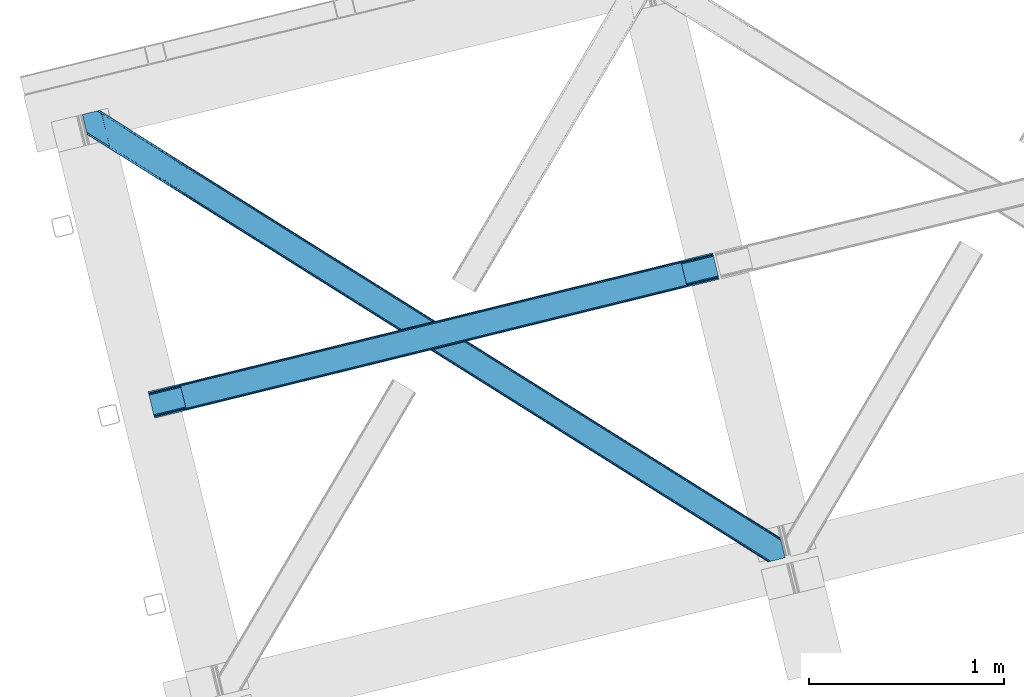
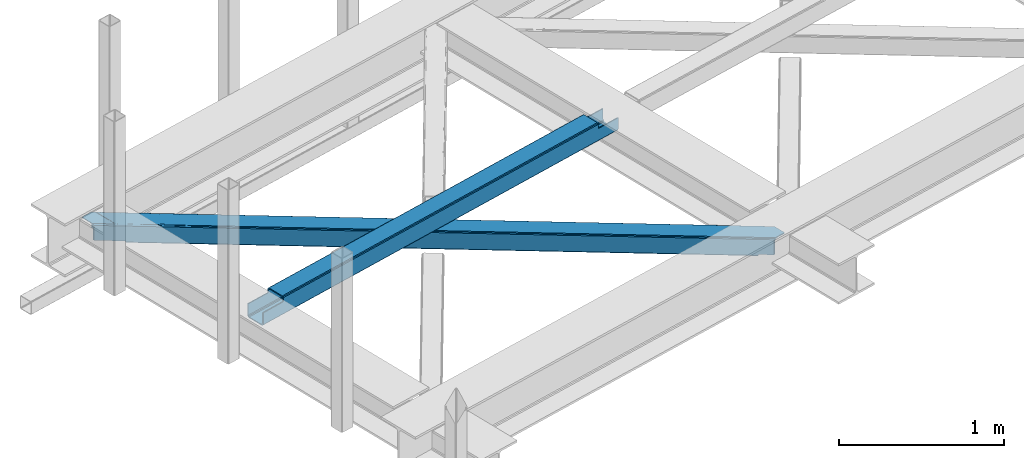
# One storey, part 18 of 67: 1 beam, 1 member.
"""IFC4 building model written with IfcOpenShell, lengths in millimetres."""

import ifcopenshell
import ifcopenshell.guid

model = None  # the IFC model being written
_history = None  # IfcOwnerHistory: only IFC2X3 demands one
_inside = {}  # id of a spatial element -> (the spatial element, [elements in it])
_under = {}  # id of a project, library or spatial element -> (it, [spatial elements below it])
_declared = {}  # id of a project -> (the project, [libraries it declares])
_typed = {}  # id of a type object -> (the type object, [elements of that type])
_made_of = {}  # id of a material, layer set ... -> (it, [elements and type objects made of it])


def new_model(schema):
    """Start an empty IFC model of exactly this schema.

    Asked for "IFC4X3", IfcOpenShell would pick the latest addendum, in which some entities
    have other attributes; the version numbers below select the first issue.
    IFC2X3 requires an IfcOwnerHistory on every rooted entity: one is made here for all.
    """
    global model, _history
    if schema == "IFC4X3":
        model = ifcopenshell.file(schema_version=(4, 3, 0, 0))
    else:
        model = ifcopenshell.file(schema=schema)
    _inside.clear()
    _under.clear()
    _declared.clear()
    _typed.clear()
    _made_of.clear()
    _history = None
    if model.schema == "IFC2X3":
        org = make("IfcOrganization", Name="unknown")
        user = make(
            "IfcPersonAndOrganization",
            ThePerson=make("IfcPerson", FamilyName="unknown"),
            TheOrganization=org,
        )
        app = make(
            "IfcApplication",
            ApplicationDeveloper=org,
            Version="unknown",
            ApplicationFullName="unknown",
            ApplicationIdentifier="unknown",
        )
        _history = make(
            "IfcOwnerHistory",
            OwningUser=user,
            OwningApplication=app,
            ChangeAction="ADDED",
            CreationDate=0,
        )
    return model


def make(cls, **values):
    """One entity of the class cls with the attributes given. An attribute that is None is left unset."""
    return model.create_entity(
        cls, **{name: value for name, value in values.items() if value is not None}
    )


def entity(cls, *values):
    """Any entity or typed value of the class cls, its attributes in the order of the schema. None: left unset."""
    e = model.create_entity(cls)
    for i, value in enumerate(values):
        if value is not None:
            e[i] = value
    return e


def rooted(cls, **values):
    """An entity with a GlobalId (a new one), such as an element, a storey or a relation."""
    return make(cls, GlobalId=ifcopenshell.guid.new(), OwnerHistory=_history, **values)


def si_unit(unit_type, name, prefix=None):
    """IfcSIUnit, for example si_unit("LENGTHUNIT", "METRE", prefix="MILLI")."""
    return make("IfcSIUnit", UnitType=unit_type, Prefix=prefix, Name=name)


def converted_unit(unit_type, name, factor, base, dimensions=None, offset=None):
    """IfcConversionBasedUnit, such as the inch: factor (a typed value) times the base unit."""
    return make(
        "IfcConversionBasedUnit"
        if offset is None
        else "IfcConversionBasedUnitWithOffset",
        ConversionOffset=offset,
        Dimensions=None
        if dimensions is None
        else entity("IfcDimensionalExponents", *dimensions),
        UnitType=unit_type,
        Name=name,
        ConversionFactor=make(
            "IfcMeasureWithUnit", ValueComponent=factor, UnitComponent=base
        ),
    )


def derived_unit(unit_type, elements):
    """IfcDerivedUnit: a product of units, each with its exponent."""
    return make(
        "IfcDerivedUnit",
        Elements=[
            make("IfcDerivedUnitElement", Unit=unit, Exponent=power)
            for unit, power in elements
        ],
        UnitType=unit_type,
    )


def assignment(units):
    """IfcUnitAssignment: the units of a project."""
    return None if units is None else make("IfcUnitAssignment", Units=units)


def point(xyz):
    """IfcCartesianPoint."""
    return None if xyz is None else make("IfcCartesianPoint", Coordinates=xyz)


def direction(xyz):
    """IfcDirection."""
    return None if xyz is None else make("IfcDirection", DirectionRatios=xyz)


def frame(location, z_axis=None, x_axis=None):
    """IfcAxis2Placement3D, a coordinate frame: its origin and axes. An axis left out is left unset."""
    return make(
        "IfcAxis2Placement3D",
        Location=point(location),
        Axis=direction(z_axis),
        RefDirection=direction(x_axis),
    )


def origin():
    """The frame at (0, 0, 0) with its axes left unset."""
    return frame((0.0, 0.0, 0.0))


def place(relative_to, where):
    """IfcLocalPlacement: puts the frame where relative to a parent placement (None: the world)."""
    return make(
        "IfcLocalPlacement", PlacementRelTo=relative_to, RelativePlacement=where
    )


def context(
    kind, dimensions, precision=None, world=None, true_north=None, identifier=None
):
    """IfcGeometricRepresentationContext, for example the 3D "Model" context."""
    return make(
        "IfcGeometricRepresentationContext",
        ContextIdentifier=identifier,
        ContextType=kind,
        CoordinateSpaceDimension=dimensions,
        Precision=precision,
        WorldCoordinateSystem=world,
        TrueNorth=true_north,
    )


def subcontext(parent, identifier, kind, view, scale=None):
    """IfcGeometricRepresentationSubContext, for example "Body" below "Model"."""
    return make(
        "IfcGeometricRepresentationSubContext",
        ContextIdentifier=identifier,
        ContextType=kind,
        ParentContext=parent,
        TargetScale=scale,
        TargetView=view,
    )


def project(units=None, contexts=None):
    """IfcProject with its units and contexts."""
    return rooted(
        "IfcProject",
        Name="project",
        RepresentationContexts=contexts,
        UnitsInContext=assignment(units),
    )


def spatial(cls, under=None, at=None, **own):
    """A site, building, storey or space (cls), placed at a placement, below another one or the project."""
    s = rooted(cls, ObjectPlacement=at, **own)
    if under is not None:
        _under.setdefault(under.id(), (under, []))[1].append(s)
    return s


def point_list(points):
    """IfcCartesianPointList2D or 3D."""
    cls = (
        "IfcCartesianPointList2D" if len(points[0]) == 2 else "IfcCartesianPointList3D"
    )
    return make(cls, CoordList=points)


def triangles(points, corners, closed=None, point_numbers=None):
    """IfcTriangulatedFaceSet: each triangle names its three corners, points numbered from 1."""
    return make(
        "IfcTriangulatedFaceSet",
        Coordinates=point_list(points),
        Closed=closed,
        CoordIndex=corners,
        PnIndex=point_numbers,
    )


def polygons(points, faces, closed=None, point_numbers=None):
    """IfcPolygonalFaceSet: a face is its outer loop, then its inner loops; points numbered from 1."""
    made = []
    for loops in faces:
        if len(loops) == 1:
            made.append(make("IfcIndexedPolygonalFace", CoordIndex=loops[0]))
        else:
            made.append(
                make(
                    "IfcIndexedPolygonalFaceWithVoids",
                    CoordIndex=loops[0],
                    InnerCoordIndices=loops[1:],
                )
            )
    return make(
        "IfcPolygonalFaceSet",
        Coordinates=point_list(points),
        Closed=closed,
        Faces=made,
        PnIndex=point_numbers,
    )


def shape(context_of_items, identifier, shape_type, items):
    """IfcShapeRepresentation: the items that make up one representation, for example the "Body"."""
    return make(
        "IfcShapeRepresentation",
        ContextOfItems=context_of_items,
        RepresentationIdentifier=identifier,
        RepresentationType=shape_type,
        Items=items,
    )


def material(Name=None, Category=None):
    """IfcMaterial."""
    return make("IfcMaterial", Name=Name, Category=Category)


def made_of(thing, what):
    """Note that an element or type object is made of a material, layer set ...; save() writes the relation."""
    if what is not None:
        _made_of.setdefault(what.id(), (what, []))[1].append(thing)
    return thing


def type_object(cls, material=None, **own):
    """A type object (cls), such as IfcWallType, which elements share."""
    return made_of(rooted(cls, **own), material)


def element(
    cls,
    number,
    at=None,
    inside=None,
    cuts=None,
    type_object=None,
    material=None,
    context=None,
    identifier="Body",
    shape_type=None,
    held_by="IfcProductDefinitionShape",
    body=None,
    shapes=None,
    **own,
):
    """One element of the class cls, such as IfcWall. Its Tag is "e" and its number.

    at: its placement. inside: the storey or other place that contains it. cuts: it is an
    opening in that element (IfcRelVoidsElement). A single representation is given by context,
    identifier, shape_type and body (its items); several are given by shapes. held_by: the class
    of the entity that holds the representations. save() writes the other relations.
    """
    e = rooted(cls, Tag="e%d" % number, ObjectPlacement=at, **own)
    if body is not None:
        shapes = [shape(context, identifier, shape_type, body)]
    if shapes is not None:
        e.Representation = make(held_by, Representations=shapes)
    if inside is not None:
        _inside.setdefault(inside.id(), (inside, []))[1].append(e)
    if cuts is not None:
        rooted(
            "IfcRelVoidsElement", RelatingBuildingElement=cuts, RelatedOpeningElement=e
        )
    if type_object is not None:
        _typed.setdefault(type_object.id(), (type_object, []))[1].append(e)
    return made_of(e, material)


def aggregate(whole, parts):
    """IfcRelAggregates: a whole, such as a stair, and the parts it consists of."""
    return rooted("IfcRelAggregates", RelatingObject=whole, RelatedObjects=parts)


def save(model, path):
    """Write the relations noted so far, then the file.

    IfcRelAggregates (storeys below a building ...), IfcRelContainedInSpatialStructure (elements
    in a storey), IfcRelDefinesByType, IfcRelAssociatesMaterial and IfcRelDeclares: one each for
    every whole, place, type object, material and project.
    """
    for whole, parts in _under.values():
        aggregate(whole, parts)
    for where, things in _inside.values():
        rooted(
            "IfcRelContainedInSpatialStructure",
            RelatedElements=things,
            RelatingStructure=where,
        )
    for kind, things in _typed.values():
        rooted("IfcRelDefinesByType", RelatedObjects=things, RelatingType=kind)
    for what, things in _made_of.values():
        rooted("IfcRelAssociatesMaterial", RelatedObjects=things, RelatingMaterial=what)
    for by, libraries in _declared.values():
        rooted("IfcRelDeclares", RelatingContext=by, RelatedDefinitions=libraries)
    model.write(path)


model = new_model("IFC4")

# Units and contexts
model_context = context("Model", 3, precision=0.01, world=origin(), true_north=direction((6.12303176911189e-17, 1.0)))
plan_context = context("Plan", 3, precision=0.01, world=origin(), true_north=direction((6.12303176911189e-17, 1.0)))
body_context = subcontext(model_context, "Body", "Model", "MODEL_VIEW")
ifc_project = project(units=[si_unit("LENGTHUNIT", "METRE", prefix="MILLI"), si_unit("AREAUNIT", "SQUARE_METRE"), si_unit("VOLUMEUNIT", "CUBIC_METRE"), converted_unit("PLANEANGLEUNIT", "DEGREE", entity("IfcRatioMeasure", 0.0174532925199433), si_unit("PLANEANGLEUNIT", "RADIAN"), dimensions=[0, 0, 0, 0, 0, 0, 0]), si_unit("MASSUNIT", "GRAM", prefix="KILO"), derived_unit("MASSDENSITYUNIT", [(si_unit("MASSUNIT", "GRAM", prefix="KILO"), 1), (si_unit("LENGTHUNIT", "METRE"), -3)]), derived_unit("MOMENTOFINERTIAUNIT", [(si_unit("LENGTHUNIT", "METRE"), 4)]), si_unit("TIMEUNIT", "SECOND"), si_unit("FREQUENCYUNIT", "HERTZ"), si_unit("THERMODYNAMICTEMPERATUREUNIT", "DEGREE_CELSIUS"), derived_unit("THERMALTRANSMITTANCEUNIT", [(si_unit("MASSUNIT", "GRAM", prefix="KILO"), 1), (si_unit("THERMODYNAMICTEMPERATUREUNIT", "KELVIN"), -1), (si_unit("TIMEUNIT", "SECOND"), -3)]), derived_unit("VOLUMETRICFLOWRATEUNIT", [(si_unit("LENGTHUNIT", "METRE"), 3), (si_unit("TIMEUNIT", "SECOND"), -1)]), derived_unit("MASSFLOWRATEUNIT", [(si_unit("MASSUNIT", "GRAM", prefix="KILO"), 1), (si_unit("TIMEUNIT", "SECOND"), -1)]), derived_unit("ROTATIONALFREQUENCYUNIT", [(si_unit("TIMEUNIT", "SECOND"), -1)]), si_unit("ELECTRICCURRENTUNIT", "AMPERE"), si_unit("ELECTRICVOLTAGEUNIT", "VOLT"), si_unit("POWERUNIT", "WATT"), si_unit("FORCEUNIT", "NEWTON", prefix="KILO"), si_unit("ILLUMINANCEUNIT", "LUX"), si_unit("LUMINOUSFLUXUNIT", "LUMEN"), si_unit("LUMINOUSINTENSITYUNIT", "CANDELA"), derived_unit("USERDEFINED", [(si_unit("MASSUNIT", "GRAM", prefix="KILO"), -1), (si_unit("LENGTHUNIT", "METRE"), -2), (si_unit("TIMEUNIT", "SECOND"), 3), (si_unit("LUMINOUSFLUXUNIT", "LUMEN"), 1)]), derived_unit("LINEARVELOCITYUNIT", [(si_unit("LENGTHUNIT", "METRE"), 1), (si_unit("TIMEUNIT", "SECOND"), -1)]), si_unit("PRESSUREUNIT", "PASCAL"), derived_unit("USERDEFINED", [(si_unit("LENGTHUNIT", "METRE"), -2), (si_unit("MASSUNIT", "GRAM", prefix="KILO"), 1), (si_unit("TIMEUNIT", "SECOND"), -2)]), derived_unit("LINEARFORCEUNIT", [(si_unit("MASSUNIT", "GRAM", prefix="KILO"), 1), (si_unit("LENGTHUNIT", "METRE"), 1), (si_unit("TIMEUNIT", "SECOND"), -2), (si_unit("LENGTHUNIT", "METRE"), -1)]), derived_unit("PLANARFORCEUNIT", [(si_unit("MASSUNIT", "GRAM", prefix="KILO"), 1), (si_unit("LENGTHUNIT", "METRE"), 1), (si_unit("TIMEUNIT", "SECOND"), -2), (si_unit("LENGTHUNIT", "METRE"), -2)])], contexts=[model_context, plan_context])

# Site, building, storey
site_placement = place(None, origin())
site = spatial("IfcSite", under=ifc_project, at=site_placement, CompositionType="ELEMENT")
building_placement = place(site_placement, origin())
building = spatial("IfcBuilding", under=site, at=building_placement, CompositionType="ELEMENT")
storey_placement = place(building_placement, frame((0.0, 0.0, 19800.0)))
storey = spatial("IfcBuildingStorey", under=building, at=storey_placement, CompositionType="ELEMENT", Elevation=19800.0)

# Beam
ifc_material = material(Name="Metal painted (White)")
beam_type = type_object("IfcBeamType", PredefinedType="BEAM")
beam_placement = place(storey_placement, frame((-60653.4760071884, 4348.08207749355, 3967.02213739951)))
element("IfcBeam", 1, at=beam_placement, inside=storey, type_object=beam_type, material=ifc_material, ObjectType="Steel Beam", PredefinedType="BEAM", context=body_context, shape_type="Tessellation", body=[
    polygons([(195.600194800813, 47.1939241264168, 116.42075398189), (195.284716026293, 48.4881398473712, 123.117713426564), (2768.48559452428, 681.870165407978, 122.252244531349), (2768.80107329879, 680.575949687031, 115.555285086674), (194.386308486354, 52.1737543987761, 128.795119546125), (2767.58718698434, 685.555779959373, 127.92965065091), (193.041746584857, 57.6896663753656, 132.588638724685), (2766.24262508284, 691.071691935965, 131.723169829474), (191.455727682833, 64.1961281805546, 133.920742055655), (2764.65660618081, 697.578153741174, 133.055273160444), (169.904498669375, 152.607589262086, 133.920675186106), (2743.10537716735, 785.989614822707, 133.055206290887), (168.318479767342, 159.114051067314, 132.588562012879), (2741.51935826532, 792.496076627916, 131.723093117668), (166.973917865845, 164.629963043904, 128.795034490451), (2740.17479636383, 798.011988604507, 127.92956559524), (166.075510325905, 168.315577595304, 123.117622795697), (2739.27638882389, 801.697603155909, 122.25215390049), (165.760031551403, 169.60979331623, 116.420661393285), (2738.96091004938, 802.991818876847, 115.55519249807), (2737.30312320219, 809.792700498506, 100.498086491908), (2737.30312320219, 809.792700498503, 122.555187727575), (2737.61860197672, 808.498484777552, 129.252149129995), (2738.51700951664, 804.81287022615, 134.929560824745), (2739.86157141814, 799.296958249559, 138.723088347173), (2741.44759032016, 792.790496444363, 140.055201520396), (2766.314393028, 690.777272119517, 140.055278677568), (2767.90041193004, 684.270810314287, 138.723175346603), (2769.24497383153, 678.754898337697, 134.929656168038), (2770.14338137147, 675.069283786296, 129.252250048477), (2770.4588601463, 673.775068064068, 122.555290603803), (2770.45886014598, 673.775068065378, 100.498086491908), (2768.80107329879, 680.575949687035, 100.498086491908), (2738.96091004938, 802.99181887685, 100.498086491908), (165.760031551403, 169.609793316229, 101.477862600484), (195.600194800813, 47.1939241264141, 101.477862600484), (197.257981650628, 40.3930424940991, 101.477862600484), (197.257981648003, 40.3930425047588, 123.420759499018), (196.942502873492, 41.687258225697, 130.117718943693), (196.044095333553, 45.3728727770981, 135.795125063254), (194.699533432056, 50.8887847536882, 139.588644241814), (193.113514530032, 57.3952465588977, 140.920747572779), (168.246711822184, 159.408470883743, 140.920670415607), (166.660692920151, 165.914932688954, 139.588557242389), (165.316131018672, 171.430844665544, 135.795029719961), (164.417723478732, 175.116459216944, 130.117618025206), (164.102244704213, 176.410674937886, 123.420656622786), (164.102244704213, 176.410674937885, 101.477862600484), (2932.903318003, 720.968992071844, 99.4980864919125), (2932.903318003, 720.968992071844, 24.5000861794985), (31.4979500966005, 6.80088174160769, 25.4759431828536), (31.4979500966005, 6.80088174160444, 100.477862600484), (194.629175601386, 46.9549120412976, 100.477862600484), (1.65778684719041, 129.216750931422, 25.4758505942489), (2903.06315475359, 843.384861261661, 24.4999935908851), (2903.06315475359, 843.384861261658, 99.4980864919125), (2739.93192924881, 803.230830961967, 99.4980864919082), (1.65778684719041, 129.216750931419, 100.477862600484), (2934.5611048484, 714.168110457467, 17.5000909499932), (2934.56110485023, 714.168110450045, 99.4980864919168), (2771.42987934575, 674.0140801491, 99.4980864919082), (33.1557369624336, 4.30769958370547e-08, 100.477862600484), (33.1557369474987, 1.04887051577407e-07, 18.4759479533483), (2901.40536790641, 850.185742883315, 99.4980864919125), (2901.4053679064, 850.185742883316, 17.4999880737653), (8.66293703438714e-12, 136.017632553077, 18.4758450771204), (-8.66293703438714e-12, 136.017632553075, 100.477862600484), (163.131225504777, 176.171662852768, 100.477862600484), (2769.77209249822, 680.814961772152, 99.4980864919125), (2738.27414240162, 810.031712583623, 99.4980864919125), (2903.37863352809, 842.090645540723, 17.8030341462194), (2904.27704106803, 838.405030989319, 12.125628026654), (2905.62160296953, 832.889119012729, 8.33210884809829), (2907.20762187156, 826.38265720752, 7.00000551712847), (2928.75885088502, 737.971196125987, 7.00007238668162), (2930.34486978705, 731.464734320777, 8.33218555990442), (2931.68943168854, 725.948822344187, 12.1257130823282), (2932.58783922849, 722.263207792786, 17.8031247770826), (2934.24562607566, 715.462326171149, 10.8031295475774), (2933.34721853572, 719.147940722552, 5.12571785282298), (2932.00265663423, 724.663852699141, 1.33219033039485), (2930.41663773221, 731.17031450433, 7.715717638348e-05), (2905.54983502437, 833.183538829176, 4.33146851719357e-12), (2903.96381612233, 839.690000634401, 1.33210333096982), (2902.61925422084, 845.20591261099, 5.12562250952989), (2901.7208466809, 848.891527162392, 10.8030286290909), (196.286962448568, 40.1540304196412, 100.477862600484), (164.789012351976, 169.370781231112, 100.477862600484), (27.3534829786202, 23.8030857957493, 7.97592939004109), (28.9395018806444, 17.2966239905593, 9.30804256325955), (30.2840637821412, 11.7807120139697, 13.1015700856834), (31.1824713220808, 8.0950974625664, 18.7789817804377), (1.97326562170153, 127.922535210493, 18.7788911495702), (2.87167316163245, 124.236920659096, 13.1014850300135), (4.21623506312922, 118.721008682505, 9.30796585145342), (5.80225396516212, 112.214546877282, 7.9758625204836), (0.315478774519784, 134.723416832139, 11.7788856324504), (1.21388631445936, 131.037802280738, 6.10147951288935), (2.5584482159388, 125.521890304147, 2.30796033432496), (4.14446711798903, 119.015428498938, 0.975857003359465), (29.0112698258193, 17.0022041740919, 0.975934160527186), (30.5972887278435, 10.4957423688823, 2.30804733374998), (31.9418506293403, 4.97983039229176, 6.10157485618245), (32.8402581692798, 1.29421584089328, 11.7789865509282)], [[[1, 2, 3, 4]], [[2, 5, 6, 3]], [[5, 7, 8, 6]], [[7, 9, 10, 8]], [[11, 12, 10, 9]], [[11, 13, 14, 12]], [[13, 15, 16, 14]], [[15, 17, 18, 16]], [[17, 19, 20, 18]], [[21, 22, 23, 24, 25, 26, 27, 28, 29, 30, 31, 32, 33, 4, 3, 6, 8, 10, 12, 14, 16, 18, 20, 34]], [[35, 19, 17, 15, 13, 11, 9, 7, 5, 2, 1, 36, 37, 38, 39, 40, 41, 42, 43, 44, 45, 46, 47, 48]], [[42, 41, 28, 27]], [[41, 40, 29, 28]], [[40, 39, 30, 29]], [[39, 38, 31, 30]], [[27, 26, 43, 42]], [[47, 46, 23, 22]], [[46, 45, 24, 23]], [[45, 44, 25, 24]], [[44, 43, 26, 25]], [[33, 49, 50, 51, 52, 53, 1, 4]], [[54, 55, 56, 57, 20, 19, 35, 58]], [[59, 60, 61, 31, 38, 37, 62, 63]], [[64, 65, 66, 67, 68, 47, 22, 21]], [[61, 60, 49, 69]], [[64, 70, 57, 56]], [[65, 64, 56, 55, 71, 72, 73, 74, 75, 76, 77, 78, 50, 49, 60, 59, 79, 80, 81, 82, 83, 84, 85, 86]], [[87, 53, 52, 62]], [[67, 58, 88, 68]], [[89, 90, 76, 75]], [[90, 91, 77, 76]], [[91, 92, 78, 77]], [[92, 51, 50, 78]], [[54, 93, 71, 55]], [[93, 94, 72, 71]], [[94, 95, 73, 72]], [[95, 96, 74, 73]], [[89, 75, 74, 96]], [[66, 97, 98, 99, 100, 101, 102, 103, 104, 63, 62, 52, 51, 92, 91, 90, 89, 96, 95, 94, 93, 54, 58, 67]], [[63, 104, 79, 59]], [[104, 103, 80, 79]], [[103, 102, 81, 80]], [[102, 101, 82, 81]], [[100, 99, 84, 83]], [[99, 98, 85, 84]], [[98, 97, 86, 85]], [[97, 66, 65, 86]], [[83, 82, 101, 100]]], closed=False),
])

# Member
member_type = type_object("IfcMemberType", PredefinedType="BRACE")
member_placement = place(storey_placement, frame((-60991.500402832, 3609.34131774902, 3823.99987792968)))
element("IfcMember", 2, at=member_placement, inside=storey, type_object=member_type, ObjectType="Steel Horizontal Brace", PredefinedType="BRACE", context=body_context, shape_type="Tessellation", body=[
    triangles([(207.717553710936, 2101.81647491455, 0.0), (172.040661621089, 2248.17905273438, 0.0), (3404.48986816406, 219.293009948731, 0.0), (3440.16676025391, 72.9304321289064, 0.0), (202.587634277341, 2097.1307144165, 1.33247680664135), (208.508203124999, 2098.57423095703, 0.155804443358647), (3442.44104003906, 63.5952461242678, 1.33247680664135), (3445.65944824219, 50.3934356689456, 10.8039916992202), (3446.115234375, 48.5365722656252, 17.5012573242202), (187.951318359374, 2093.56290893555, 17.5012573242202), (189.755859375, 2094.00299835205, 10.8039916992202), (3444.37115478516, 55.6811943054204, 5.12526855468968), (194.895080566406, 2095.25582885742, 5.12526855468968), (3405.08983154297, 238.005530548096, 10.8039916992202), (3400.22036132812, 236.818103027344, 5.32758178711083), (167.836267089842, 2265.42799987793, 5.12526855468968), (166.547973632813, 2270.71604919434, 10.8039916992202), (3400.29477539063, 236.497192382813, 5.1694519042976), (3402.21558837891, 228.628195953369, 1.33247680664135), (169.766381835936, 2257.51394805908, 1.33247680664135), (3406.89437255859, 238.4456199646, 17.5012573242202), (166.092187499999, 2272.57291259766, 17.5012573242202), (3401.18774414063, 237.055007171631, 18.5197998046897), (3406.89437255859, 238.4456199646, 18.5197998046897), (3400.50406494141, 236.887575531006, 18.2267944335945), (3400.82032470703, 236.964315032959, 18.4453857421868), (3400.29012451172, 236.836125183106, 17.9035583496116), (3400.22036132812, 236.818103027344, 17.5198608398459), (3402.03885498047, 231.951248931885, 18.4453857421868), (3401.8388671875, 231.936424255372, 18.1454040527351), (3401.62027587891, 231.920146179199, 17.8198425292976), (3401.6109741211, 231.919564819336, 17.8058898925774), (3401.41563720703, 231.905030822754, 17.5198608398459), (3402.49464111328, 231.698357391358, 18.5197998046897), (3586.9019897461, 125.462400054932, 18.5197998046897), (3589.63670654297, 114.236631774902, 18.5197998046897), (204.378222656247, 2097.56731567383, 12.1248413085959), (208.508203124999, 2098.57423095703, 9.69243164062573), (199.648278808592, 2096.4150604248, 17.9802978515618), (198.420446777345, 2096.11566009521, 19.5011352539077), (187.951318359374, 2093.56290893555, 19.5011352539077), (25.3054321289019, 2195.64679412842, 19.5011352539077), (22.6823364257798, 2206.42113647461, 19.5011352539077), (3437.79016113281, 82.6876853942872, 6.99957275390625), (3404.5921875, 218.870652008057, 8.3320495605476), (3402.6620727539, 226.784703826905, 12.1248413085959), (3406.86646728516, 209.535466003418, 6.99957275390625), (3443.24099121094, 60.3181205749515, 17.5198608398459), (3441.99455566406, 65.4387382507325, 12.1248413085959), (3446.115234375, 48.5365722656252, 17.5198608398459), (3440.06444091797, 73.3527900695804, 8.3320495605476), (1232.85963134765, 1574.07833862305, 6.99957275390625), (640.584155273435, 1945.82774047852, 6.99957275390625), (602.800415039063, 1862.1026184082, 6.99957275390625), (1195.07589111328, 1490.35496063232, 6.99957275390625), (1825.13510742188, 1202.32951812744, 6.99957275390625), (1787.3467163086, 1118.60788421631, 6.99957275390625), (205.340954589839, 2111.57401885986, 6.99957275390625), (174.417260742186, 2238.42150878906, 6.99957275390625), (2971.89301757813, 375.112859344483, 6.99957275390625), (3009.68605957031, 458.831295776367, 6.99957275390625), (2379.62219238281, 746.86022644043, 6.99957275390625), (2417.41058349609, 830.580406951905, 6.99957275390625), (168.831555175777, 2261.33697052002, 18.501196289064), (166.092187499999, 2272.57291259766, 18.501196289064), (168.966430664063, 2260.78526000977, 17.8803039550803), (170.212866210939, 2255.67045593262, 12.1248413085959), (172.142980957033, 2247.75640411377, 8.3320495605476), (207.559423828126, 2102.47631835938, 8.8831787109375), (3444.59439697266, 58.9995964050295, 18.5197998046897), (3447.32911376953, 47.7738281250004, 18.5197998046897), (3447.04075927734, 47.9543403625489, 18.2849304199226), (3444.26883544922, 59.3173095703128, 18.2802795410171), (3446.71984863281, 48.1552001953128, 18.0198303222678), (3443.91536865234, 59.6588584899905, 18.0198303222678), (3446.40358886719, 48.3560600280766, 17.757055664064), (3443.62701416016, 59.9419807434083, 17.8058898925774), (3443.56655273437, 60.0004074096682, 17.7617065429695), (3534.35635986328, 2.65972137451172, 18.5197998046897), (3523.44539794922, 0.0, 18.5197998046897), (2962.59125976563, 360.290798950195, 24.5008300781265), (2963.29819335938, 361.418927764893, 17.8035644531265), (3532.92854003907, 2.31177749633798, 24.5008300781265), (2965.31667480469, 364.632103729248, 12.1248413085959), (596.224072265621, 1851.62128143311, 12.1248413085959), (599.242492675781, 1856.43029022217, 8.3320495605476), (594.205590820311, 1848.40868682861, 17.8035644531265), (593.498657226563, 1847.28026733398, 24.5008300781265), (22.9288330078125, 2205.40433807373, 24.5008300781265), (2968.33509521485, 369.440821838379, 8.3320495605476), (2370.3157836914, 732.038166046143, 24.5008300781265), (2371.02736816406, 733.16629486084, 17.8035644531265), (1778.75189208984, 1104.91366195679, 17.8035644531265), (1778.0449584961, 1103.78553314209, 24.5008300781265), (1186.48106689453, 1476.66102905273, 17.8035644531265), (1185.76948242187, 1475.53260955811, 24.5008300781265), (2373.04119873047, 736.379470825196, 12.1248413085959), (1780.77037353515, 1108.12683792114, 12.1248413085959), (1188.49489746094, 1479.87420501709, 12.1248413085959), (2376.05961914062, 741.188188934326, 8.3320495605476), (1783.78879394531, 1112.93555603027, 8.3320495605476), (1191.51331787109, 1484.68263244629, 8.3320495605476), (2965.14924316407, 350.42105255127, 122.499499511719), (2371.32037353516, 723.143650817872, 122.499499511719), (3523.44539794922, 0.0, 122.499499511719), (1777.49150390625, 1095.86624908447, 122.499499511719), (1183.66728515625, 1468.58884735107, 122.499499511719), (589.838415527345, 1841.31144561768, 122.499499511719), (25.3054321289019, 2195.64679412842, 122.499499511719), (3532.92854003907, 2.31177749633798, 115.499926757813), (22.9288330078125, 2205.40433807373, 115.499926757813), (3534.73308105468, 2.75157623291034, 122.197192382813), (22.4776977539077, 2207.26120147705, 122.197192382813), (3539.87230224609, 4.00440673828143, 127.873590087893), (21.1894042968706, 2212.54925079346, 127.873590087893), (3547.56485595703, 5.87958297729529, 131.668707275392), (19.2592895507769, 2220.46330261231, 131.668707275392), (3556.63872070312, 8.09136657714862, 133.001184082033), (16.9803588867144, 2229.79819793701, 133.001184082033), (3525.24993896484, 0.439798736572357, 129.196765136719), (3530.38916015625, 1.69262924194345, 134.87548828125), (3547.15557861328, 5.77958908081064, 140.00075683594), (3612.207421875, 21.6376327514649, 140.00075683594), (3612.207421875, 21.6376327514649, 133.001184082033), (3538.08171386718, 3.5678054809573, 138.668280029298), (168.515295410158, 2261.63113861084, 18.7407165527366), (165.808483886714, 2272.75313415527, 18.7360656738274), (168.171130371091, 2261.94914245606, 19.0011657714858), (165.487573242186, 2272.95428466797, 19.0011657714858), (167.826965332031, 2262.26714630127, 19.2592895507805), (165.166662597658, 2273.1548538208, 19.2639404296897), (167.506054687496, 2262.56131439209, 19.5011352539077), (164.878308105464, 2273.33565673828, 19.5011352539077), (78.2928955078096, 2318.55673370361, 19.5011352539077), (88.7666748046831, 2321.10948486328, 19.5011352539077), (649.178979492186, 1959.52167205811, 17.8035644531265), (3018.28088378906, 472.525227355957, 17.8035644531265), (3016.26705322265, 469.312051391602, 12.1248413085959), (3018.99246826172, 473.653356170655, 24.5008300781265), (3589.27858886719, 115.704856109619, 24.5008300781265), (649.885913085935, 1960.64951019287, 24.5008300781265), (79.2788818359331, 2318.79741668701, 24.5008300781265), (3013.2486328125, 464.503333282471, 8.3320495605476), (644.142077636716, 1951.49948730469, 8.3320495605476), (647.160498046876, 1956.30849609375, 12.1248413085959), (2420.97315673828, 836.252444458008, 8.3320495605476), (1828.69768066406, 1208.00155563355, 8.3320495605476), (1236.42220458984, 1579.75066680908, 8.3320495605476), (2423.99157714844, 841.061162567139, 12.1248413085959), (1831.71610107422, 1212.81027374268, 12.1248413085959), (1239.440625, 1584.55909423828, 12.1248413085959), (2426.00540771485, 844.274338531495, 17.8035644531265), (1833.72993164062, 1216.02344970703, 17.8035644531265), (1241.4544555664, 1587.77227020264, 17.8035644531265), (2426.7169921875, 845.402467346191, 24.5008300781265), (1834.43686523438, 1217.15157852173, 24.5008300781265), (1242.16138916015, 1588.90068969727, 24.5008300781265), (1247.70523681641, 1593.6864440918, 122.499499511719), (653.811254882814, 1966.45031890869, 122.499499511719), (1841.59921875, 1220.9225692749, 122.499499511719), (3586.9019897461, 125.462400054932, 122.499499511719), (2435.4932006836, 848.158403778076, 122.499499511719), (3029.38253173828, 475.39423828125, 122.499499511719), (88.7666748046831, 2321.10948486328, 122.499499511719), (3591.02266845703, 108.559943389893, 127.873590087893), (3588.64141845703, 118.317487335205, 134.87548828125), (3590.57153320313, 110.403726196289, 138.668280029298), (3592.94813232422, 100.646182250977, 131.668707275392), (3595.22706298828, 91.3109962463382, 133.001184082033), (3592.84581298828, 101.068540191651, 140.00075683594), (3589.734375, 113.847992706299, 122.197192382813), (3587.353125, 123.605536651612, 129.196765136719), (3589.27858886719, 115.704856109619, 115.499926757813), (55.5687011718765, 2313.01811828613, 133.001184082033), (0.0, 2299.47185211182, 133.001184082033), (79.2788818359331, 2318.79741668701, 115.499926757813), (64.6425659179658, 2315.22961120606, 131.668707275392), (72.3351196289077, 2317.105078125, 127.873590087893), (77.474340820314, 2318.35790863037, 122.197192382813), (76.0604736328096, 2318.01316223145, 138.000878906252), (81.8229125976577, 2319.41656494141, 134.87548828125), (86.962133789064, 2320.66939544678, 129.196765136719), (0.0, 2299.47185211182, 138.000878906252), (24.8542968749971, 2197.50365753174, 129.196765136719), (23.5660034179673, 2202.79170684815, 134.87548828125), (22.1195800781206, 2208.71634521484, 138.000878906252), (98.1893554687485, 2304.12331237793, 138.000878906252), (139.386840820313, 2135.11211700439, 138.000878906252), (599.144824218747, 1856.1337966919, 140.00075683594), (139.824023437497, 2137.54568939209, 139.000817871096), (140.051916503908, 2136.3818069458, 138.668280029298), (137.842749023439, 2145.67368164063, 140.00075683594), (592.563830566403, 1845.6524597168, 134.87548828125), (139.805419921875, 2135.0249130249, 138.075292968751), (595.582250976564, 1850.46146850586, 138.668280029298), (139.917041015622, 2135.65917663574, 138.352020263672), (140.033312988278, 2136.29576568604, 138.631072998047), (2974.45100097657, 365.243403625489, 140.00075683594), (2970.88842773438, 359.571075439454, 138.668280029298), (2967.87000732422, 354.762357330323, 134.87548828125), (2965.85617675781, 351.549181365967, 129.196765136719), (590.549999999996, 1842.43986511231, 129.196765136719), (2372.0273071289, 724.2720703125, 129.196765136719), (1778.2030883789, 1096.99437789917, 129.196765136719), (1184.37421875, 1469.7172668457, 129.196765136719), (2374.04578857421, 727.484955596924, 134.87548828125), (1780.21691894531, 1100.20755386353, 134.87548828125), (1186.39270019531, 1472.93044281006, 134.87548828125), (2377.06420898438, 732.293673706055, 138.668280029298), (1783.23533935547, 1105.01627197266, 138.668280029298), (1189.41112060547, 1477.73887023926, 138.668280029298), (2380.62213134766, 737.965711212158, 140.00075683594), (1786.79791259766, 1110.68830947876, 140.00075683594), (1192.96904296875, 1483.41119842529, 140.00075683594), (651.085839843749, 1962.10930480957, 134.87548828125), (98.7056030273452, 2303.62683105469, 138.075292968751), (99.1985961914033, 2302.47515716553, 138.384576416018), (648.067419433595, 1957.30087738037, 138.668280029298), (99.5985717773438, 2301.53800506592, 138.633398437501), (644.509497070314, 1951.62854919434, 140.00075683594), (100.184582519527, 2300.16425170898, 139.000817871096), (102.165856933592, 2292.03625946045, 140.00075683594), (3028.67559814453, 474.266109466553, 129.196765136719), (3026.66176757812, 471.052933502197, 134.87548828125), (3023.64334716797, 466.244215393067, 138.668280029298), (3020.08077392578, 460.572177886963, 140.00075683594), (653.104321289058, 1965.32248077393, 129.196765136719), (2429.74936523438, 839.008380889893, 138.668280029298), (2426.18679199219, 833.336052703858, 140.00075683594), (1832.2974609375, 1206.10021820068, 140.00075683594), (1835.85538330078, 1211.77254638672, 138.668280029298), (1238.40347900391, 1578.86409301758, 140.00075683594), (1241.96140136719, 1584.53642120361, 138.668280029298), (2432.76778564453, 843.817098999024, 134.87548828125), (1838.87380371094, 1216.58126449585, 134.87548828125), (1244.97982177734, 1589.34484863281, 134.87548828125), (2434.78161621094, 847.030274963379, 129.196765136719), (1840.89228515625, 1219.79414978027, 129.196765136719), (1246.99830322265, 1592.55802459717, 129.196765136719)], [[1, 2, 3], [3, 4, 1], [5, 6, 4], [4, 7, 5], [8, 9, 10], [10, 11, 8], [12, 8, 11], [11, 13, 12], [7, 12, 13], [13, 5, 7], [6, 1, 4], [14, 15, 16], [16, 17, 14], [18, 19, 20], [19, 3, 2], [2, 20, 19], [20, 16, 18], [15, 18, 16], [21, 14, 17], [17, 22, 21], [23, 21, 24], [25, 23, 26], [23, 25, 27], [23, 27, 28], [21, 23, 28], [28, 15, 14], [14, 21, 28], [26, 29, 30], [25, 30, 31], [27, 32, 33], [27, 31, 32], [33, 28, 27], [31, 27, 25], [30, 25, 26], [23, 34, 29], [29, 26, 23], [34, 24, 35], [24, 34, 23], [35, 36, 34], [37, 38, 5], [37, 5, 13], [13, 11, 39], [38, 6, 5], [39, 37, 13], [11, 10, 40], [41, 40, 10], [11, 40, 39], [42, 43, 40], [40, 41, 42], [3, 44, 4], [45, 19, 46], [33, 15, 28], [18, 33, 46], [33, 18, 15], [3, 19, 45], [46, 19, 18], [3, 47, 44], [45, 47, 3], [8, 48, 9], [48, 12, 49], [12, 48, 8], [50, 9, 48], [49, 7, 51], [51, 4, 44], [4, 51, 7], [49, 12, 7], [52, 53, 54], [54, 55, 52], [55, 56, 52], [56, 55, 57], [53, 58, 54], [53, 59, 58], [60, 61, 62], [61, 60, 47], [44, 47, 60], [63, 62, 61], [57, 63, 56], [62, 63, 57], [17, 22, 64], [22, 65, 64], [66, 17, 64], [66, 16, 17], [67, 16, 66], [20, 67, 68], [67, 20, 16], [2, 20, 68], [68, 59, 2], [69, 38, 6], [69, 1, 58], [1, 59, 58], [59, 1, 2], [69, 6, 1], [70, 71, 72], [72, 73, 70], [73, 72, 74], [74, 75, 73], [75, 76, 77], [75, 74, 76], [76, 78, 77], [78, 76, 50], [50, 48, 78], [71, 70, 79], [79, 80, 71], [81, 70, 73], [73, 82, 81], [73, 75, 82], [75, 77, 82], [83, 79, 70], [70, 81, 83], [82, 77, 78], [78, 84, 82], [78, 48, 84], [48, 49, 84], [54, 58, 69], [85, 86, 38], [86, 69, 38], [87, 85, 37], [88, 87, 39], [39, 40, 88], [88, 40, 89], [43, 89, 40], [37, 39, 87], [38, 37, 85], [69, 86, 54], [51, 44, 90], [60, 90, 44], [49, 51, 84], [90, 84, 51], [81, 82, 91], [92, 91, 82], [91, 92, 93], [93, 94, 91], [94, 93, 95], [95, 96, 94], [96, 95, 87], [87, 88, 96], [82, 84, 97], [97, 92, 82], [92, 97, 98], [98, 93, 92], [93, 98, 99], [99, 95, 93], [95, 99, 85], [85, 87, 95], [84, 90, 100], [100, 97, 84], [97, 100, 101], [101, 98, 97], [98, 101, 102], [102, 99, 98], [99, 102, 86], [86, 85, 99], [90, 60, 100], [62, 100, 60], [100, 62, 101], [57, 101, 62], [101, 57, 102], [55, 102, 57], [102, 55, 86], [54, 86, 55], [9, 103, 104], [71, 105, 72], [71, 80, 105], [105, 74, 72], [50, 105, 103], [50, 76, 105], [76, 74, 105], [9, 50, 103], [106, 10, 9], [10, 107, 108], [109, 41, 108], [106, 107, 10], [106, 9, 104], [10, 108, 41], [42, 41, 109], [81, 110, 83], [110, 81, 91], [110, 94, 111], [94, 110, 91], [88, 89, 111], [96, 111, 94], [111, 96, 88], [112, 110, 111], [111, 113, 112], [114, 112, 113], [113, 115, 114], [116, 114, 115], [115, 117, 116], [118, 116, 117], [117, 119, 118], [112, 120, 121], [118, 122, 123], [123, 124, 118], [118, 116, 122], [116, 125, 122], [114, 125, 116], [121, 125, 114], [112, 105, 120], [110, 105, 112], [121, 114, 112], [80, 83, 79], [110, 80, 105], [83, 80, 110], [65, 64, 126], [126, 127, 65], [127, 126, 128], [128, 129, 127], [129, 128, 130], [130, 131, 129], [131, 130, 132], [132, 133, 131], [134, 135, 133], [133, 132, 134], [136, 66, 67], [137, 138, 33], [138, 46, 33], [139, 29, 34], [34, 140, 139], [34, 36, 140], [139, 137, 32], [32, 31, 139], [30, 29, 139], [139, 31, 30], [141, 130, 128], [141, 132, 130], [128, 136, 141], [64, 136, 126], [128, 126, 136], [64, 66, 136], [132, 141, 142], [142, 134, 132], [33, 32, 137], [45, 46, 143], [138, 143, 46], [47, 45, 61], [143, 61, 45], [53, 144, 59], [68, 59, 144], [144, 145, 68], [67, 68, 145], [67, 145, 136], [61, 143, 146], [146, 63, 61], [63, 146, 147], [147, 56, 63], [56, 147, 148], [148, 52, 56], [52, 148, 144], [144, 53, 52], [143, 138, 146], [149, 146, 138], [146, 149, 147], [150, 147, 149], [147, 150, 148], [151, 148, 150], [148, 151, 144], [145, 144, 151], [138, 137, 152], [152, 149, 138], [149, 152, 153], [153, 150, 149], [150, 153, 154], [154, 151, 150], [151, 154, 136], [136, 145, 151], [137, 139, 152], [155, 152, 139], [152, 155, 153], [156, 153, 155], [153, 156, 154], [157, 154, 156], [154, 157, 136], [141, 136, 157], [158, 22, 159], [22, 158, 160], [161, 35, 24], [21, 160, 162], [21, 163, 24], [160, 21, 22], [24, 163, 161], [162, 163, 21], [164, 159, 65], [164, 65, 127], [22, 65, 159], [129, 164, 127], [164, 129, 131], [131, 133, 164], [135, 164, 133], [165, 166, 167], [165, 167, 168], [169, 168, 170], [171, 166, 165], [124, 169, 123], [170, 123, 169], [168, 167, 170], [172, 166, 171], [35, 161, 173], [140, 35, 173], [35, 140, 36], [172, 171, 161], [171, 173, 161], [119, 174, 169], [174, 119, 175], [169, 118, 119], [124, 118, 169], [156, 173, 176], [173, 155, 139], [156, 155, 173], [139, 140, 173], [157, 176, 141], [176, 157, 156], [142, 141, 176], [168, 169, 174], [174, 177, 168], [165, 168, 177], [177, 178, 165], [171, 165, 178], [178, 179, 171], [173, 171, 179], [179, 176, 173], [177, 174, 180], [181, 178, 180], [177, 180, 178], [179, 181, 182], [174, 183, 180], [174, 175, 183], [179, 178, 181], [164, 176, 179], [176, 164, 135], [142, 135, 134], [135, 142, 176], [164, 179, 182], [111, 42, 109], [184, 113, 109], [113, 184, 185], [113, 111, 109], [89, 42, 111], [43, 42, 89], [115, 113, 185], [186, 119, 117], [119, 186, 183], [183, 175, 119], [117, 115, 186], [186, 115, 185], [180, 186, 187], [180, 183, 186], [188, 187, 186], [189, 190, 191], [189, 192, 190], [193, 194, 188], [188, 185, 193], [188, 186, 185], [195, 196, 194], [195, 191, 196], [194, 193, 195], [197, 195, 189], [125, 122, 198], [198, 199, 125], [121, 125, 199], [199, 200, 121], [120, 121, 200], [200, 201, 120], [105, 120, 201], [201, 103, 105], [108, 202, 109], [184, 109, 202], [202, 193, 184], [185, 184, 193], [103, 201, 104], [203, 104, 201], [104, 203, 204], [204, 106, 104], [106, 204, 205], [205, 107, 106], [107, 205, 108], [202, 108, 205], [201, 200, 203], [206, 203, 200], [203, 206, 204], [207, 204, 206], [204, 207, 208], [208, 205, 204], [205, 208, 193], [193, 202, 205], [200, 199, 209], [209, 206, 200], [206, 209, 210], [210, 207, 206], [207, 210, 208], [211, 208, 210], [208, 211, 193], [195, 193, 211], [199, 198, 212], [212, 209, 199], [209, 212, 213], [213, 210, 209], [210, 213, 214], [214, 211, 210], [211, 214, 189], [189, 195, 211], [215, 216, 217], [217, 218, 215], [217, 219, 218], [187, 215, 181], [181, 180, 187], [219, 220, 218], [219, 221, 220], [221, 222, 220], [172, 161, 223], [163, 223, 161], [166, 172, 224], [223, 224, 172], [167, 166, 225], [224, 225, 166], [170, 167, 226], [225, 226, 167], [215, 227, 182], [182, 181, 215], [227, 159, 164], [164, 182, 227], [226, 225, 228], [228, 229, 226], [229, 228, 230], [231, 230, 228], [230, 231, 232], [233, 232, 231], [232, 233, 218], [218, 220, 232], [225, 224, 234], [234, 228, 225], [228, 234, 235], [235, 231, 228], [231, 235, 236], [236, 233, 231], [233, 236, 215], [215, 218, 233], [224, 223, 234], [237, 234, 223], [234, 237, 235], [238, 235, 237], [235, 238, 236], [239, 236, 238], [236, 239, 215], [227, 215, 239], [223, 163, 162], [162, 237, 223], [237, 162, 160], [160, 238, 237], [238, 160, 158], [158, 239, 238], [239, 158, 159], [159, 227, 239], [214, 232, 189], [232, 214, 230], [213, 230, 214], [230, 213, 229], [222, 192, 220], [189, 220, 192], [220, 189, 232], [170, 226, 198], [198, 122, 170], [123, 170, 122], [226, 212, 198], [212, 229, 213], [226, 229, 212], [197, 190, 221], [221, 219, 197], [219, 217, 194], [217, 216, 194], [222, 221, 192], [190, 192, 221]]),
])

save(model, "model.ifc")
